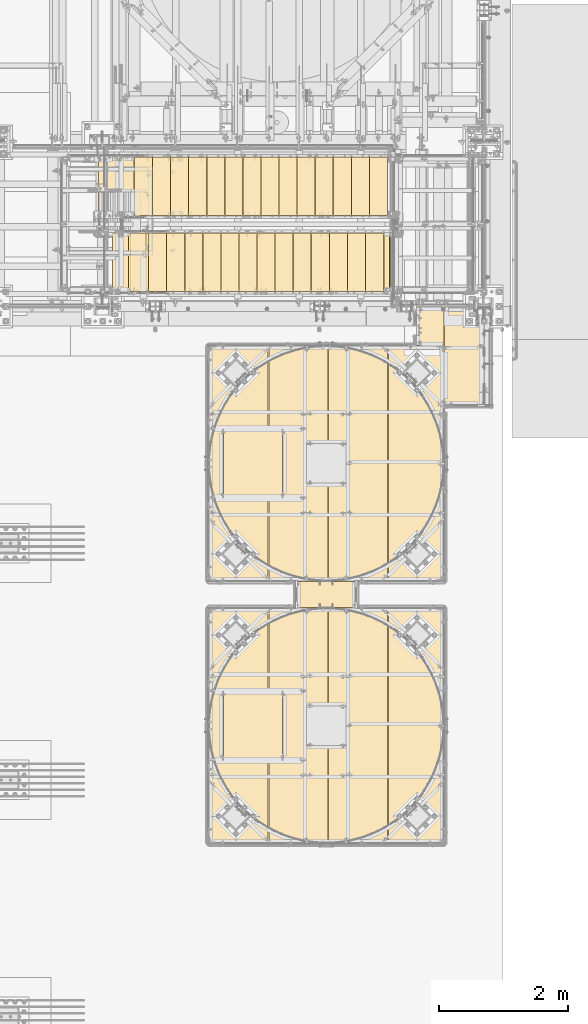
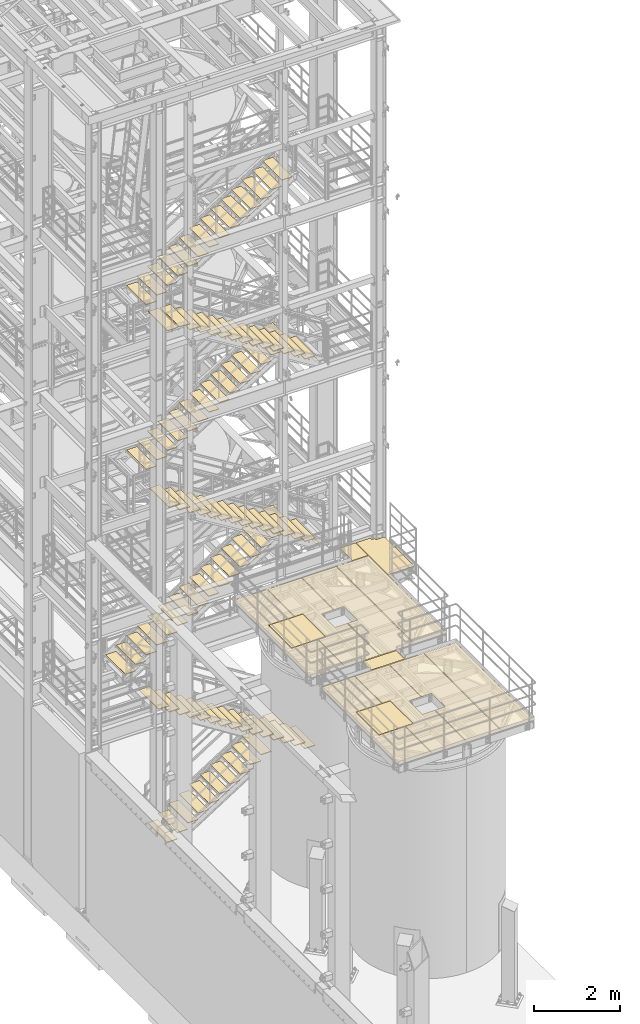
# One storey, part 1875 of 1876: 113 coverings.
"""IFC2X3 building model written with IfcOpenShell, lengths in millimetres."""

from ifc_helpers import new_model, si_unit, frame, origin_with_axes, place, context, subcontext, project, spatial, faceted_brep, material, element, save


model = new_model("IFC2X3")

# Units and contexts
model_context = context("Model", 3, precision=1e-05, world=origin_with_axes())
body_context = subcontext(model_context, "Body", "Model", "MODEL_VIEW")
ifc_project = project(units=[si_unit("LENGTHUNIT", "METRE", prefix="MILLI"), si_unit("AREAUNIT", "SQUARE_METRE"), si_unit("VOLUMEUNIT", "CUBIC_METRE"), si_unit("MASSUNIT", "GRAM", prefix="KILO"), si_unit("TIMEUNIT", "SECOND"), si_unit("PLANEANGLEUNIT", "RADIAN"), si_unit("SOLIDANGLEUNIT", "STERADIAN"), si_unit("THERMODYNAMICTEMPERATUREUNIT", "DEGREE_CELSIUS"), si_unit("LUMINOUSINTENSITYUNIT", "LUMEN")], contexts=[model_context])

# Site, building, storey
site_placement = place(None, origin_with_axes())
site = spatial("IfcSite", under=ifc_project, at=site_placement, CompositionType="ELEMENT")
building_placement = place(site_placement, origin_with_axes())
building = spatial("IfcBuilding", under=site, at=building_placement, Name="Undefined", CompositionType="ELEMENT")
storey_placement = place(building_placement, origin_with_axes())
storey = spatial("IfcBuildingStorey", under=building, at=storey_placement, Name="Undefined", CompositionType="ELEMENT", Elevation=0.0)

# Coverings
ifc_material_1 = material(Name="Undefined/Zero_Density")
covering_1_placement = place(storey_placement, frame((6572.25000460266, -7131.05000084384, 8022.4315), z_axis=(1.0, 0.0, 0.0), x_axis=(0.0, -1.0, 0.0)))
element("IfcCovering", 1, at=covering_1_placement, inside=storey, material=ifc_material_1, Name="SurfaceTreatment", PredefinedType="NOTDEFINED", context=body_context, shape_type="Brep", body=[
    faceted_brep([(7.36690708436072e-11, -0.793499999999767, 427.039367675781), (584.164367675789, -0.793499999999767, 427.039367675769), (584.164367675789, 0.793499999999767, 427.039367675769), (7.36690708436072e-11, 0.793499999999767, 427.039367675781), (584.164367675781, -0.793499999999767, -1.2732925824821e-11), (584.164367675781, 0.793499999999767, -1.2732925824821e-11), (9.09494701772928e-13, -0.793499999999767, 0.0), (9.09494701772928e-13, 0.793499999999767, 0.0)], [[[0, 1, 2, 3]], [[1, 4, 5, 2]], [[4, 6, 7, 5]], [[6, 0, 3, 7]], [[5, 7, 3, 2]], [[6, 4, 1, 0]]]),
])
covering_2_placement = place(storey_placement, frame((5640.38894370825, -11761.7518981934, 8022.4315), z_axis=(-0.999999995651566, -9.32569999677071e-05, 0.0), x_axis=(-9.32569999670443e-05, 0.999999995651566, 0.0)))
element("IfcCovering", 2, at=covering_2_placement, inside=storey, material=ifc_material_1, Name="SurfaceTreatment", PredefinedType="NOTDEFINED", context=body_context, shape_type="Brep", body=[
    faceted_brep([(0.144186362498658, -0.793499999999767, 909.63751220718), (397.016265868699, -0.793499999999767, 909.600463867374), (397.016265868699, 0.793499999999767, 909.600463867374), (0.144186362498658, 0.793499999999767, 909.63751220718), (396.840850829822, -0.793499999999767, -1.35514710564166e-10), (396.840850829822, 0.793499999999767, -1.35514710564166e-10), (9.09494701772928e-13, -0.793499999999767, 0.0), (9.09494701772928e-13, 0.793499999999767, 0.0)], [[[0, 1, 2, 3]], [[1, 4, 5, 2]], [[4, 6, 7, 5]], [[6, 0, 3, 7]], [[5, 7, 3, 2]], [[6, 4, 1, 0]]]),
])
covering_3_placement = place(storey_placement, frame((7004.05187319314, -7715.21439251548, 8022.4315), z_axis=(1.0, 0.0, 0.0), x_axis=(0.0, -1.0, 0.0)))
element("IfcCovering", 3, at=covering_3_placement, inside=storey, material=ifc_material_1, Name="SurfaceTreatment", PredefinedType="NOTDEFINED", context=body_context, shape_type="Brep", body=[
    faceted_brep([(-4.25638972956222e-07, -0.793499999999767, -0.00187377934707911), (-584.164367675781, -0.793499999999767, -0.00187527816342481), (-584.164367675781, 0.793499999999767, -0.00187527816342481), (-4.25638972956222e-07, 0.793499999999767, -0.00187377934707911), (-584.164367675614, -0.793499999999767, 382.585601806901), (-584.164367675614, 0.793499999999767, 382.585601806901), (-514.314392089676, -0.793499999999767, 382.585601806869), (-514.314392089676, 0.793499999999767, 382.585601806869), (-514.314392089638, -0.793499999999767, 468.310638427963), (-514.314392089638, 0.793499999999767, 468.310638427963), (-460.339385986123, -0.793499999999767, 468.310638427938), (-460.339385986123, 0.793499999999767, 468.310638427938), (-460.339385986022, -0.793499999999767, 698.498168945516), (-460.339385986022, 0.793499999999767, 698.498168945516), (914.435607910462, -0.793499999999767, 698.498168944898), (914.435607910462, 0.793499999999767, 698.498168944898), (914.435607910154, -0.793499999999767, -4.14729584008455e-10), (914.435607910154, 0.793499999999767, -4.14729584008455e-10)], [[[0, 1, 2, 3]], [[1, 4, 5, 2]], [[4, 6, 7, 5]], [[6, 8, 9, 7]], [[8, 10, 11, 9]], [[10, 12, 13, 11]], [[12, 14, 15, 13]], [[14, 16, 17, 15]], [[16, 0, 3, 17]], [[5, 7, 9, 11, 13, 15, 17, 3, 2]], [[16, 14, 12, 10, 8, 6, 4, 1, 0]]]),
])
covering_4_placement = place(storey_placement, frame((4876.80473825666, -9232.86440429625, 8022.4315), z_axis=(0.0, 1.0, 0.0), x_axis=(1.0, 0.0, 0.0)))
element("IfcCovering", 4, at=covering_4_placement, inside=storey, material=ifc_material_1, Name="SurfaceTreatment", PredefinedType="NOTDEFINED", context=body_context, shape_type="Brep", body=[
    faceted_brep([(327.027099609375, -0.793499999999767, -2114.49365234375), (-582.6103515625, -0.793499999999767, -2114.49365234375), (-582.6103515625, 0.793499999999767, -2114.49365234375), (327.027099609375, 0.793499999999767, -2114.49365234375), (-582.6103515625, -0.793499999999767, -841.374938964844), (-582.6103515625, 0.793499999999767, -841.374938964844), (-368.299987792969, -0.793499999999767, -841.374938964844), (-368.299987792969, 0.793499999999767, -841.374938964844), (-368.299987792969, -0.793499999999767, 231.77507019043), (-368.299987792969, 0.793499999999767, 231.77507019043), (-582.6103515625, -0.793499999999767, 231.77507019043), (-582.6103515625, 0.793499999999767, 231.77507019043), (-582.6103515625, -0.793499999999767, 1505.00939941406), (-582.6103515625, 0.793499999999767, 1505.00939941406), (327.027099609375, -0.793499999999767, 1505.00939941406), (327.027099609375, 0.793499999999767, 1505.00939941406), (327.027099609375, -0.793499999999767, 0.0), (327.027099609375, 0.793499999999767, 0.0), (9.09494701772928e-13, -0.793499999999767, 0.0), (9.09494701772928e-13, 0.793499999999767, 0.0), (0.0, -0.793499999999767, -609.599975585938), (0.0, 0.793499999999767, -609.599975585938), (327.027099609375, -0.793499999999767, -609.599975585938), (327.027099609375, 0.793499999999767, -609.599975585938)], [[[0, 1, 2, 3]], [[1, 4, 5, 2]], [[4, 6, 7, 5]], [[6, 8, 9, 7]], [[8, 10, 11, 9]], [[10, 12, 13, 11]], [[12, 14, 15, 13]], [[14, 16, 17, 15]], [[16, 18, 19, 17]], [[18, 20, 21, 19]], [[20, 22, 23, 21]], [[22, 0, 3, 23]], [[5, 7, 9, 11, 13, 15, 17, 19, 21, 23, 3, 2]], [[22, 20, 18, 16, 14, 12, 10, 8, 6, 4, 1, 0]]]),
])
covering_5_placement = place(storey_placement, frame((3592.51891061995, -9007.43935546873, 8022.4315), z_axis=(1.0, 0.0, 0.0), x_axis=(0.0, -1.0, 0.0)))
element("IfcCovering", 5, at=covering_5_placement, inside=storey, material=ifc_material_1, Name="SurfaceTreatment", PredefinedType="NOTDEFINED", context=body_context, shape_type="Brep", body=[
    faceted_brep([(0.0, -0.793499999999767, 909.637512207031), (1060.45007324219, -0.793499999999767, 909.637512207031), (1060.45007324219, 0.793499999999767, 909.637512207031), (0.0, 0.793499999999767, 909.637512207031), (1060.45007324219, -0.793499999999767, 0.0), (1060.45007324219, 0.793499999999767, 0.0), (9.09494701772928e-13, -0.793499999999767, 0.0), (9.09494701772928e-13, 0.793499999999767, 0.0)], [[[0, 1, 2, 3]], [[1, 4, 5, 2]], [[4, 6, 7, 5]], [[6, 0, 3, 7]], [[5, 7, 3, 2]], [[6, 4, 1, 0]]]),
])
covering_6_placement = place(storey_placement, frame((6142.07478332581, -7727.91436167475, 8022.4315), z_axis=(0.999999999962502, -8.65999999950873e-06, 0.0), x_axis=(-8.6599999995572e-06, -0.999999999962502, 0.0)))
element("IfcCovering", 6, at=covering_6_placement, inside=storey, material=ifc_material_1, Name="SurfaceTreatment", PredefinedType="NOTDEFINED", context=body_context, shape_type="Brep", body=[
    faceted_brep([(-0.00731827155505016, -0.793499999999767, 849.277099609553), (3619.43627929786, -0.793499999999767, 849.308471678866), (3619.43627929786, 0.793499999999767, 849.308471678866), (-0.00731827155505016, 0.793499999999767, 849.277099609553), (3619.44360351638, -0.793499999999767, -1.96450855582952e-09), (3619.44360351638, 0.793499999999767, -1.96450855582952e-09), (9.09494701772928e-13, -0.793499999999767, 0.0), (9.09494701772928e-13, 0.793499999999767, 0.0)], [[[0, 1, 2, 3]], [[1, 4, 5, 2]], [[4, 6, 7, 5]], [[6, 0, 3, 7]], [[5, 7, 3, 2]], [[6, 4, 1, 0]]]),
])
covering_7_placement = place(storey_placement, frame((5216.53091929245, -11347.3580079976, 8022.43150000058), z_axis=(0.0, 1.0, 0.0), x_axis=(1.0, 0.0, 0.0)))
element("IfcCovering", 7, at=covering_7_placement, inside=storey, material=ifc_material_1, Name="SurfaceTreatment", PredefinedType="NOTDEFINED", context=body_context, shape_type="Brep", body=[
    faceted_brep([(0.0130641348341669, -0.793499999999767, 1504.89599609375), (269.873809814421, -0.793499999999767, 1504.8936767576), (269.873809814421, 0.793499999999767, 1504.8936767576), (0.0130641348341669, 0.793499999999767, 1504.89599609375), (269.87380981447, -0.793499999999767, 2114.55151367176), (269.87380981447, 0.793499999999767, 2114.55151367176), (0.0183281973177145, -0.793499999999767, 2114.55151367197), (0.0183281973177145, 0.793499999999767, 2114.55151367197), (0.0313720779013238, -0.793499999999767, 3619.44360351597), (0.0313720779013238, 0.793499999999767, 3619.44360351597), (909.668884277481, -0.793499999999767, 3619.44360351525), (909.668884277481, 0.793499999999767, 3619.44360351525), (909.637512206879, -0.793499999999767, -9.60426405072212e-10), (909.637512206879, 0.793499999999767, -9.60426405072212e-10), (9.09494701772928e-13, -0.793499999999767, 0.0), (9.09494701772928e-13, 0.793499999999767, 0.0)], [[[0, 1, 2, 3]], [[1, 4, 5, 2]], [[4, 6, 7, 5]], [[6, 8, 9, 7]], [[8, 10, 11, 9]], [[10, 12, 13, 11]], [[12, 14, 15, 13]], [[14, 0, 3, 15]], [[5, 7, 9, 11, 13, 15, 3, 2]], [[14, 12, 10, 8, 6, 4, 1, 0]]]),
])
covering_8_placement = place(storey_placement, frame((4281.49144479969, -9001.0330810547, 8022.4315), z_axis=(-1.0, 0.0, 0.0), x_axis=(0.0, 1.0, 0.0)))
element("IfcCovering", 8, at=covering_8_placement, inside=storey, material=ifc_material_1, Name="SurfaceTreatment", PredefinedType="NOTDEFINED", context=body_context, shape_type="Brep", body=[
    faceted_brep([(-1073.15063476562, -0.793499999999767, -5.18411980010569e-11), (-2346.32470703125, -0.793499999999767, -1.12777343019843e-10), (-2346.32470703125, 0.793499999999767, -1.12777343019843e-10), (-1073.15063476562, 0.793499999999767, -5.18411980010569e-11), (-2346.32470703125, -0.793499999999767, 909.637451171875), (-2346.32470703125, 0.793499999999767, 909.637451171875), (1273.17810058594, -0.793499999999767, 909.606201171875), (1273.17810058594, 0.793499999999767, 909.606201171875), (1273.17810058594, -0.793499999999767, 6.09361450187862e-11), (1273.17810058594, 0.793499999999767, 6.09361450187862e-11), (9.09494701772928e-13, -0.793499999999767, 0.0), (9.09494701772928e-13, 0.793499999999767, 0.0), (0.0, -0.793499999999767, 700.086669921875), (0.0, 0.793499999999767, 700.086669921875), (-1073.15063476562, -0.793499999999767, 700.086669921875), (-1073.15063476562, 0.793499999999767, 700.086669921875)], [[[0, 1, 2, 3]], [[1, 4, 5, 2]], [[4, 6, 7, 5]], [[6, 8, 9, 7]], [[8, 10, 11, 9]], [[10, 12, 13, 11]], [[12, 14, 15, 13]], [[14, 0, 3, 15]], [[5, 7, 9, 11, 13, 15, 3, 2]], [[14, 12, 10, 8, 6, 4, 1, 0]]]),
])
covering_9_placement = place(storey_placement, frame((4876.80142382026, -13284.1644531244, 8022.4315), z_axis=(0.0, 1.0, 0.0), x_axis=(1.0, 0.0, 0.0)))
element("IfcCovering", 9, at=covering_9_placement, inside=storey, material=ifc_material_1, Name="SurfaceTreatment", PredefinedType="NOTDEFINED", context=body_context, shape_type="Brep", body=[
    faceted_brep([(327.027099609375, -0.793499999999767, -2114.49365234375), (-582.6103515625, -0.793499999999767, -2114.49365234375), (-582.6103515625, 0.793499999999767, -2114.49365234375), (327.027099609375, 0.793499999999767, -2114.49365234375), (-582.6103515625, -0.793499999999767, -841.374938964844), (-582.6103515625, 0.793499999999767, -841.374938964844), (-368.299987792969, -0.793499999999767, -841.374938964844), (-368.299987792969, 0.793499999999767, -841.374938964844), (-368.299987792969, -0.793499999999767, 231.77507019043), (-368.299987792969, 0.793499999999767, 231.77507019043), (-582.6103515625, -0.793499999999767, 231.77507019043), (-582.6103515625, 0.793499999999767, 231.77507019043), (-582.6103515625, -0.793499999999767, 1505.00939941406), (-582.6103515625, 0.793499999999767, 1505.00939941406), (327.027099609375, -0.793499999999767, 1505.00939941406), (327.027099609375, 0.793499999999767, 1505.00939941406), (327.027099609375, -0.793499999999767, 0.0), (327.027099609375, 0.793499999999767, 0.0), (9.09494701772928e-13, -0.793499999999767, 0.0), (9.09494701772928e-13, 0.793499999999767, 0.0), (0.0, -0.793499999999767, -609.599975585938), (0.0, 0.793499999999767, -609.599975585938), (327.027099609375, -0.793499999999767, -609.599975585938), (327.027099609375, 0.793499999999767, -609.599975585938)], [[[0, 1, 2, 3]], [[1, 4, 5, 2]], [[4, 6, 7, 5]], [[6, 8, 9, 7]], [[8, 10, 11, 9]], [[10, 12, 13, 11]], [[12, 14, 15, 13]], [[14, 16, 17, 15]], [[16, 18, 19, 17]], [[18, 20, 21, 19]], [[20, 22, 23, 21]], [[22, 0, 3, 23]], [[5, 7, 9, 11, 13, 15, 17, 19, 21, 23, 3, 2]], [[22, 20, 18, 16, 14, 12, 10, 8, 6, 4, 1, 0]]]),
])
covering_10_placement = place(storey_placement, frame((3592.51559618354, -13058.7394042969, 8022.4315), z_axis=(1.0, 0.0, 0.0), x_axis=(0.0, -1.0, 0.0)))
element("IfcCovering", 10, at=covering_10_placement, inside=storey, material=ifc_material_1, Name="SurfaceTreatment", PredefinedType="NOTDEFINED", context=body_context, shape_type="Brep", body=[
    faceted_brep([(0.0, -0.793499999999767, 909.637512207031), (1060.45007324219, -0.793499999999767, 909.637512207031), (1060.45007324219, 0.793499999999767, 909.637512207031), (0.0, 0.793499999999767, 909.637512207031), (1060.45007324219, -0.793499999999767, 0.0), (1060.45007324219, 0.793499999999767, 0.0), (9.09494701772928e-13, -0.793499999999767, 0.0), (9.09494701772928e-13, 0.793499999999767, 0.0)], [[[0, 1, 2, 3]], [[1, 4, 5, 2]], [[4, 6, 7, 5]], [[6, 0, 3, 7]], [[5, 7, 3, 2]], [[6, 4, 1, 0]]]),
])
covering_11_placement = place(storey_placement, frame((6142.07146888941, -11779.2144470212, 8022.4315), z_axis=(0.999999999962502, -8.65999999950873e-06, 0.0), x_axis=(-8.6599999995572e-06, -0.999999999962502, 0.0)))
element("IfcCovering", 11, at=covering_11_placement, inside=storey, material=ifc_material_1, Name="SurfaceTreatment", PredefinedType="NOTDEFINED", context=body_context, shape_type="Brep", body=[
    faceted_brep([(-0.00731827155505016, -0.793499999999767, 849.277099609553), (3619.43627929476, -0.793499999999767, 849.308410644945), (3619.43627929476, 0.793499999999767, 849.308410644945), (-0.00731827155505016, 0.793499999999767, 849.277099609553), (3619.44360351638, -0.793499999999767, -1.96450855582952e-09), (3619.44360351638, 0.793499999999767, -1.96450855582952e-09), (9.09494701772928e-13, -0.793499999999767, 0.0), (9.09494701772928e-13, 0.793499999999767, 0.0)], [[[0, 1, 2, 3]], [[1, 4, 5, 2]], [[4, 6, 7, 5]], [[6, 0, 3, 7]], [[5, 7, 3, 2]], [[6, 4, 1, 0]]]),
])
covering_12_placement = place(storey_placement, frame((5216.52760485741, -15398.6580568249, 8022.43150000058), z_axis=(0.0, 1.0, 0.0), x_axis=(1.0, 0.0, 0.0)))
element("IfcCovering", 12, at=covering_12_placement, inside=storey, material=ifc_material_1, Name="SurfaceTreatment", PredefinedType="NOTDEFINED", context=body_context, shape_type="Brep", body=[
    faceted_brep([(0.0130641348341669, -0.793499999999767, 1504.89599609375), (269.873809814421, -0.793499999999767, 1504.8936767576), (269.873809814421, 0.793499999999767, 1504.8936767576), (0.0130641348341669, 0.793499999999767, 1504.89599609375), (269.87380981447, -0.793499999999767, 2114.55151367176), (269.87380981447, 0.793499999999767, 2114.55151367176), (0.0183281973177145, -0.793499999999767, 2114.55151367197), (0.0183281973177145, 0.793499999999767, 2114.55151367197), (0.0313720779013238, -0.793499999999767, 3619.44360351597), (0.0313720779013238, 0.793499999999767, 3619.44360351597), (909.668884277481, -0.793499999999767, 3619.44360351525), (909.668884277481, 0.793499999999767, 3619.44360351525), (909.637512206879, -0.793499999999767, -9.60426405072212e-10), (909.637512206879, 0.793499999999767, -9.60426405072212e-10), (9.09494701772928e-13, -0.793499999999767, 0.0), (9.09494701772928e-13, 0.793499999999767, 0.0)], [[[0, 1, 2, 3]], [[1, 4, 5, 2]], [[4, 6, 7, 5]], [[6, 8, 9, 7]], [[8, 10, 11, 9]], [[10, 12, 13, 11]], [[12, 14, 15, 13]], [[14, 0, 3, 15]], [[5, 7, 9, 11, 13, 15, 3, 2]], [[14, 12, 10, 8, 6, 4, 1, 0]]]),
])
covering_13_placement = place(storey_placement, frame((4281.48813036329, -13052.3331298828, 8022.4315), z_axis=(-1.0, 0.0, 0.0), x_axis=(0.0, 1.0, 0.0)))
element("IfcCovering", 13, at=covering_13_placement, inside=storey, material=ifc_material_1, Name="SurfaceTreatment", PredefinedType="NOTDEFINED", context=body_context, shape_type="Brep", body=[
    faceted_brep([(-1073.15063476562, -0.793499999999767, -5.18411980010569e-11), (-2346.32470703125, -0.793499999999767, -1.12777343019843e-10), (-2346.32470703125, 0.793499999999767, -1.12777343019843e-10), (-1073.15063476562, 0.793499999999767, -5.18411980010569e-11), (-2346.32470703125, -0.793499999999767, 909.637451171875), (-2346.32470703125, 0.793499999999767, 909.637451171875), (1273.17810058594, -0.793499999999767, 909.606201171875), (1273.17810058594, 0.793499999999767, 909.606201171875), (1273.17810058594, -0.793499999999767, 6.09361450187862e-11), (1273.17810058594, 0.793499999999767, 6.09361450187862e-11), (9.09494701772928e-13, -0.793499999999767, 0.0), (9.09494701772928e-13, 0.793499999999767, 0.0), (0.0, -0.793499999999767, 700.086669921875), (0.0, 0.793499999999767, 700.086669921875), (-1073.15063476562, -0.793499999999767, 700.086669921875), (-1073.15063476562, 0.793499999999767, 700.086669921875)], [[[0, 1, 2, 3]], [[1, 4, 5, 2]], [[4, 6, 7, 5]], [[6, 8, 9, 7]], [[8, 10, 11, 9]], [[10, 12, 13, 11]], [[12, 14, 15, 13]], [[14, 0, 3, 15]], [[5, 7, 9, 11, 13, 15, 3, 2]], [[14, 12, 10, 8, 6, 4, 1, 0]]]),
])
for number, where, z_axis, x_axis, name in (
    (14, (3270.25000124689, -5973.76300114732, 15213.6592592597), (0.0, -1.0, 0.0), (-1.0, 0.0, 0.0), "SurfaceTreatment"),
    (15, (5848.34999716895, -5710.23700114169, 17810.1037047545), (0.0, 1.0, 0.0), (1.0, 0.0, 0.0), "SurfaceTreatment"),
    (16, (5568.94999692322, -5710.23700114223, 17637.0074083463), (0.0, 1.0, 0.0), (1.0, 0.0, 0.0), "SurfaceTreatment"),
    (17, (5289.5499966775, -5710.23700114276, 17463.9111119382), (0.0, 1.0, 0.0), (1.0, 0.0, 0.0), "SurfaceTreatment"),
    (18, (5010.14999643177, -5710.23700114329, 17290.81481553), (0.0, 1.0, 0.0), (1.0, 0.0, 0.0), "SurfaceTreatment"),
    (19, (4730.74999618604, -5710.23700114382, 17117.7185191218), (0.0, 1.0, 0.0), (1.0, 0.0, 0.0), "SurfaceTreatment"),
    (20, (4451.34999594032, -5710.23700114436, 16944.6222227137), (0.0, 1.0, 0.0), (1.0, 0.0, 0.0), "SurfaceTreatment"),
    (21, (4171.94999569459, -5710.23700114489, 16771.5259263055), (0.0, 1.0, 0.0), (1.0, 0.0, 0.0), "SurfaceTreatment"),
    (22, (3892.54999544887, -5710.23700114542, 16598.4296298974), (0.0, 1.0, 0.0), (1.0, 0.0, 0.0), "SurfaceTreatment"),
    (23, (3613.14999520314, -5710.23700114596, 16425.3333334892), (0.0, 1.0, 0.0), (1.0, 0.0, 0.0), "SurfaceTreatment"),
    (24, (3333.74999495741, -5710.23700114644, 16252.2370370811), (0.0, 1.0, 0.0), (1.0, 0.0, 0.0), "SurfaceTreatment"),
    (25, (3054.34999471169, -5710.23700114697, 16079.1407406729), (0.0, 1.0, 0.0), (1.0, 0.0, 0.0), "SurfaceTreatment"),
    (26, (2774.94999446596, -5710.2370011475, 15906.0444442647), (0.0, 1.0, 0.0), (1.0, 0.0, 0.0), "SurfaceTreatment"),
    (27, (2495.54999422024, -5710.23700114804, 15732.9481478566), (0.0, 1.0, 0.0), (1.0, 0.0, 0.0), "SurfaceTreatment"),
    (28, (3549.65000116849, -5973.76300114727, 15040.5629629634), (0.0, -1.0, 0.0), (-1.0, 0.0, 0.0), "SurfaceTreatment"),
    (29, (3829.05000109009, -5973.76300114701, 14867.4666666671), (0.0, -1.0, 0.0), (-1.0, 0.0, 0.0), "SurfaceTreatment"),
    (30, (2990.85000132529, -5973.76300114758, 15386.755555556), (0.0, -1.0, 0.0), (-1.0, 0.0, 0.0), "SurfaceTreatment"),
    (31, (4108.45000101169, -5973.76300114696, 14694.3703703708), (0.0, -1.0, 0.0), (-1.0, 0.0, 0.0), "SurfaceTreatment"),
    (32, (4387.85000093329, -5973.76300114669, 14521.2740740745), (0.0, -1.0, 0.0), (-1.0, 0.0, 0.0), "SurfaceTreatment"),
    (33, (4667.25000085489, -5973.76300114664, 14348.1777777782), (0.0, -1.0, 0.0), (-1.0, 0.0, 0.0), "SurfaceTreatment"),
    (34, (4946.65000077649, -5973.76300114638, 14175.0814814819), (0.0, -1.0, 0.0), (-1.0, 0.0, 0.0), "SurfaceTreatment"),
    (35, (5226.05000069809, -5973.76300114633, 14001.9851851856), (0.0, -1.0, 0.0), (-1.0, 0.0, 0.0), "SurfaceTreatment"),
    (36, (5505.45000061969, -5973.76300114607, 13828.8888888893), (0.0, -1.0, 0.0), (-1.0, 0.0, 0.0), "SurfaceTreatment"),
    (37, (5784.85000054129, -5973.76300114601, 13655.792592593), (0.0, -1.0, 0.0), (-1.0, 0.0, 0.0), "SurfaceTreatment"),
    (38, (6064.25000046289, -5973.76300114575, 13482.6962962967), (0.0, -1.0, 0.0), (-1.0, 0.0, 0.0), "SurfaceTreatment"),
    (39, (5848.35000008514, -5710.23700114557, 13137.7266666865), (0.0, 1.0, 0.0), (1.0, 0.0, 0.0), "SurfaceTreatment"),
    (40, (5568.95000017887, -5710.23700114557, 12965.8533333532), (0.0, 1.0, 0.0), (1.0, 0.0, 0.0), "SurfaceTreatment"),
    (41, (5289.55000027259, -5710.23700114557, 12793.9800000199), (0.0, 1.0, 0.0), (1.0, 0.0, 0.0), "SurfaceTreatment"),
    (42, (5010.15000036631, -5710.23700114557, 12622.1066666865), (0.0, 1.0, 0.0), (1.0, 0.0, 0.0), "SurfaceTreatment"),
    (43, (4730.75000046003, -5710.23700114557, 12450.2333333532), (0.0, 1.0, 0.0), (1.0, 0.0, 0.0), "SurfaceTreatment"),
    (44, (4451.35000055376, -5710.23700114557, 12278.3600000199), (0.0, 1.0, 0.0), (1.0, 0.0, 0.0), "SurfaceTreatment"),
    (45, (4171.95000064748, -5710.23700114557, 12106.4866666865), (0.0, 1.0, 0.0), (1.0, 0.0, 0.0), "SurfaceTreatment"),
    (46, (3892.5500007412, -5710.23700114557, 11934.6133333532), (0.0, 1.0, 0.0), (1.0, 0.0, 0.0), "SurfaceTreatment"),
    (47, (3613.15000083493, -5710.23700114557, 11762.7400000199), (0.0, 1.0, 0.0), (1.0, 0.0, 0.0), "SurfaceTreatment"),
    (48, (3333.75000092865, -5710.23700114557, 11590.8666666865), (0.0, 1.0, 0.0), (1.0, 0.0, 0.0), "SurfaceTreatment"),
    (49, (3054.35000102237, -5710.23700114557, 11418.9933333532), (0.0, 1.0, 0.0), (1.0, 0.0, 0.0), "SurfaceTreatment"),
    (50, (2774.95000111609, -5710.23700114557, 11247.1200000199), (0.0, 1.0, 0.0), (1.0, 0.0, 0.0), "SurfaceTreatment"),
    (51, (2495.55000120982, -5710.23700114557, 11075.2466666865), (0.0, 1.0, 0.0), (1.0, 0.0, 0.0), "SurfaceTreatment"),
    (52, (2216.15000130354, -5710.23700114557, 10903.3733333532), (0.0, 1.0, 0.0), (1.0, 0.0, 0.0), "SurfaceTreatment"),
    (53, (2432.05000121991, -5973.76300114394, 10559.6266675622), (0.0, -1.0, 0.0), (-1.0, 0.0, 0.0), "SurfaceTreatment"),
    (54, (2711.45000115037, -5973.76300114419, 10387.753334165), (0.0, -1.0, 0.0), (-1.0, 0.0, 0.0), "SurfaceTreatment"),
    (55, (2990.85000108083, -5973.76300114444, 10215.8800007678), (0.0, -1.0, 0.0), (-1.0, 0.0, 0.0), "SurfaceTreatment"),
    (56, (3270.25000101129, -5973.7630011447, 10044.0066673706), (0.0, -1.0, 0.0), (-1.0, 0.0, 0.0), "SurfaceTreatment"),
    (57, (3549.65000094175, -5973.76300114495, 9872.13333397344), (0.0, -1.0, 0.0), (-1.0, 0.0, 0.0), "SurfaceTreatment"),
    (58, (3829.05000087221, -5973.7630011452, 9700.26000057626), (0.0, -1.0, 0.0), (-1.0, 0.0, 0.0), "SurfaceTreatment"),
    (59, (4108.45000080267, -5973.76300114546, 9528.38666717907), (0.0, -1.0, 0.0), (-1.0, 0.0, 0.0), "SurfaceTreatment"),
    (60, (4387.85000073313, -5973.76300114571, 9356.51333378189), (0.0, -1.0, 0.0), (-1.0, 0.0, 0.0), "SurfaceTreatment"),
    (61, (4667.25000066359, -5973.76300114597, 9184.64000038471), (0.0, -1.0, 0.0), (-1.0, 0.0, 0.0), "SurfaceTreatment"),
    (62, (4946.65000059405, -5973.76300114622, 9012.76666698753), (0.0, -1.0, 0.0), (-1.0, 0.0, 0.0), "SurfaceTreatment"),
    (63, (5226.05000052451, -5973.76300114647, 8840.89333359034), (0.0, -1.0, 0.0), (-1.0, 0.0, 0.0), "SurfaceTreatment"),
    (64, (5505.45000045497, -5973.76300114673, 8669.02000019316), (0.0, -1.0, 0.0), (-1.0, 0.0, 0.0), "SurfaceTreatment"),
    (65, (5784.85000038543, -5973.76300114698, 8497.14666679598), (0.0, -1.0, 0.0), (-1.0, 0.0, 0.0), "SurfaceTreatment"),
    (66, (6064.25000031588, -5973.76300114723, 8325.27333339879), (0.0, -1.0, 0.0), (-1.0, 0.0, 0.0), "SurfaceTreatment"),
    (67, (5848.34999446524, -5710.23700113625, 7975.5999987069), (0.0, 1.0, 0.0), (1.0, 0.0, 0.0), "SurfaceTreatment"),
    (68, (5568.94999485534, -5710.23700113625, 7797.79999878767), (0.0, 1.0, 0.0), (1.0, 0.0, 0.0), "SurfaceTreatment"),
    (69, (5289.54999524543, -5710.23700113625, 7619.99999886843), (0.0, 1.0, 0.0), (1.0, 0.0, 0.0), "SurfaceTreatment"),
    (70, (5010.14999563552, -5710.23700113625, 7442.1999989492), (0.0, 1.0, 0.0), (1.0, 0.0, 0.0), "SurfaceTreatment"),
    (71, (4730.74999602562, -5710.23700113625, 7264.39999902997), (0.0, 1.0, 0.0), (1.0, 0.0, 0.0), "SurfaceTreatment"),
    (72, (4451.34999641571, -5710.23700113625, 7086.59999911074), (0.0, 1.0, 0.0), (1.0, 0.0, 0.0), "SurfaceTreatment"),
    (73, (4171.94999680581, -5710.23700113625, 6908.7999991915), (0.0, 1.0, 0.0), (1.0, 0.0, 0.0), "SurfaceTreatment"),
    (74, (3892.5499971959, -5710.23700113625, 6730.99999927227), (0.0, 1.0, 0.0), (1.0, 0.0, 0.0), "SurfaceTreatment"),
    (75, (3613.14999758599, -5710.23700113625, 6553.19999935304), (0.0, 1.0, 0.0), (1.0, 0.0, 0.0), "SurfaceTreatment"),
    (76, (3333.74999797608, -5710.23700113625, 6375.39999943381), (0.0, 1.0, 0.0), (1.0, 0.0, 0.0), "SurfaceTreatment"),
    (77, (3054.34999836618, -5710.23700113625, 6197.59999951457), (0.0, 1.0, 0.0), (1.0, 0.0, 0.0), "SurfaceTreatment"),
    (78, (2774.94999875627, -5710.23700113625, 6019.79999959534), (0.0, 1.0, 0.0), (1.0, 0.0, 0.0), "SurfaceTreatment"),
    (79, (2495.54999914636, -5710.23700113625, 5841.99999967611), (0.0, 1.0, 0.0), (1.0, 0.0, 0.0), "SurfaceTreatment"),
    (80, (2216.14999953646, -5710.23700113625, 5664.19999975688), (0.0, 1.0, 0.0), (1.0, 0.0, 0.0), "SurfaceTreatment"),
    (81, (1936.74999992655, -5710.23700113625, 5486.39999983764), (0.0, 1.0, 0.0), (1.0, 0.0, 0.0), "SurfaceTreatment"),
    (82, (1657.35000031664, -5710.23700113625, 5308.59999991841), (0.0, 1.0, 0.0), (1.0, 0.0, 0.0), "SurfaceTreatment"),
    (83, (2152.65000578957, -5973.76300113422, 4953.5474137952), (0.0, -1.0, 0.0), (-1.0, 0.0, 0.0), "SurfaceTreatment"),
    (84, (2432.05000547176, -5973.76300113406, 4776.29482758856), (0.0, -1.0, 0.0), (-1.0, 0.0, 0.0), "SurfaceTreatment"),
    (85, (2711.45000515396, -5973.76300113389, 4599.04224138192), (0.0, -1.0, 0.0), (-1.0, 0.0, 0.0), "SurfaceTreatment"),
    (86, (2990.85000483615, -5973.76300113373, 4421.78965517528), (0.0, -1.0, 0.0), (-1.0, 0.0, 0.0), "SurfaceTreatment"),
    (87, (3270.25000451835, -5973.76300113357, 4244.53706896864), (0.0, -1.0, 0.0), (-1.0, 0.0, 0.0), "SurfaceTreatment"),
    (88, (3549.65000420054, -5973.76300113341, 4067.28448276199), (0.0, -1.0, 0.0), (-1.0, 0.0, 0.0), "SurfaceTreatment"),
    (89, (3829.05000388274, -5973.76300113325, 3890.03189655535), (0.0, -1.0, 0.0), (-1.0, 0.0, 0.0), "SurfaceTreatment"),
    (90, (4108.45000356493, -5973.76300113309, 3712.77931034871), (0.0, -1.0, 0.0), (-1.0, 0.0, 0.0), "SurfaceTreatment"),
    (91, (4387.85000324712, -5973.76300113293, 3535.52672414207), (0.0, -1.0, 0.0), (-1.0, 0.0, 0.0), "SurfaceTreatment"),
    (92, (4667.25000292932, -5973.76300113277, 3358.27413793542), (0.0, -1.0, 0.0), (-1.0, 0.0, 0.0), "SurfaceTreatment"),
    (93, (4946.65000261151, -5973.76300113261, 3181.02155172878), (0.0, -1.0, 0.0), (-1.0, 0.0, 0.0), "SurfaceTreatment"),
    (94, (5226.05000229371, -5973.76300113245, 3003.76896552214), (0.0, -1.0, 0.0), (-1.0, 0.0, 0.0), "SurfaceTreatment"),
    (95, (5505.4500019759, -5973.76300113228, 2826.5163793155), (0.0, -1.0, 0.0), (-1.0, 0.0, 0.0), "SurfaceTreatment"),
    (96, (5784.85000165809, -5973.76300113212, 2649.26379310885), (0.0, -1.0, 0.0), (-1.0, 0.0, 0.0), "SurfaceTreatment"),
    (97, (6064.25000134029, -5973.76300113196, 2472.01120690221), (0.0, -1.0, 0.0), (-1.0, 0.0, 0.0), "SurfaceTreatment"),
    (98, (5848.35000066187, -5710.23700121136, 2117.50603396813), (0.0, 1.0, 0.0), (1.0, 0.0, 0.0), "SurfaceTreatment"),
    (99, (5289.55000060753, -5710.23700121136, 1763.00086163999), (0.0, 1.0, 0.0), (1.0, 0.0, 0.0), "SurfaceTreatment"),
    (100, (5010.15000058036, -5710.23700121136, 1585.74827547592), (0.0, 1.0, 0.0), (1.0, 0.0, 0.0), "SurfaceTreatment"),
    (101, (4730.75000055319, -5710.23700121136, 1408.49568931185), (0.0, 1.0, 0.0), (1.0, 0.0, 0.0), "SurfaceTreatment"),
    (102, (4451.35000052602, -5710.23700121136, 1231.24310314779), (0.0, 1.0, 0.0), (1.0, 0.0, 0.0), "SurfaceTreatment"),
    (103, (4171.95000049885, -5710.23700121136, 1053.99051698372), (0.0, 1.0, 0.0), (1.0, 0.0, 0.0), "SurfaceTreatment"),
    (104, (3892.55000047169, -5710.23700121136, 876.737930819678), (0.0, 1.0, 0.0), (1.0, 0.0, 0.0), "SurfaceTreatment"),
    (105, (3613.15000044451, -5710.23700121136, 699.485344655642), (0.0, 1.0, 0.0), (1.0, 0.0, 0.0), "SurfaceTreatment"),
    (106, (3333.75000041734, -5710.23700121136, 522.232758491605), (0.0, 1.0, 0.0), (1.0, 0.0, 0.0), "SurfaceTreatment"),
    (107, (3054.35000039017, -5710.23700121136, 344.980172327555), (0.0, 1.0, 0.0), (1.0, 0.0, 0.0), "SurfaceTreatment"),
    (108, (2774.950000363, -5710.23700121136, 167.727586163495), (0.0, 1.0, 0.0), (1.0, 0.0, 0.0), "SurfaceTreatment"),
):
    element("IfcCovering", number, at=place(storey_placement, frame(where, z_axis=z_axis, x_axis=x_axis)), inside=storey, material=ifc_material_1, Name=name, PredefinedType="NOTDEFINED", context=body_context, shape_type="Brep", body=[
        faceted_brep([(-9.09494701772928e-13, -9.525, -1.81898940354586e-12), (0.0, -9.52499999999964, 904.8740234375), (0.0, 9.52499999999964, 904.8740234375), (-9.09494701772928e-13, 9.525, -1.81898940354586e-12), (276.225006103516, -9.52499999999964, 904.8740234375), (276.225006103516, 9.52499999999964, 904.8740234375), (276.225006103516, -9.52499999999964, 0.0), (276.225006103516, 9.52499999999964, 0.0)], [[[0, 1, 2, 3]], [[1, 4, 5, 2]], [[4, 6, 7, 5]], [[6, 0, 3, 7]], [[5, 7, 3, 2]], [[6, 4, 1, 0]]]),
    ])
ifc_material_2 = material(Name="Undefined/Tiles")
covering_14_placement = place(storey_placement, frame((6172.19999694572, -5975.34987682352, 8162.42500058556), z_axis=(0.0, -1.0, 0.0), x_axis=(-1.0, 0.0, 0.0)))
element("IfcCovering", 109, at=covering_14_placement, inside=storey, material=ifc_material_2, Name="SurfaceTreatment", PredefinedType="NOTDEFINED", context=body_context, shape_type="Brep", body=[
    faceted_brep([(0.0, -0.5, 901.700012207031), (101.599998474121, -0.5, 901.700012207031), (101.599998474121, 0.5, 901.700012207031), (0.0, 0.5, 901.700012207031), (101.599998474121, -0.5, 0.0), (101.599998474121, 0.5, 0.0), (0.0, -0.5, 0.0), (0.0, 0.5, 0.0)], [[[0, 1, 2, 3]], [[1, 4, 5, 2]], [[4, 6, 7, 5]], [[6, 0, 3, 7]], [[5, 7, 3, 2]], [[6, 4, 1, 0]]]),
])
covering_15_placement = place(storey_placement, frame((6159.49999998204, -5975.35000104997, 13318.6250005856), z_axis=(0.0, -1.0, 0.0), x_axis=(-1.0, 0.0, 0.0)))
element("IfcCovering", 110, at=covering_15_placement, inside=storey, material=ifc_material_2, Name="SurfaceTreatment", PredefinedType="NOTDEFINED", context=body_context, shape_type="Brep", body=[
    faceted_brep([(0.0, -0.5, 901.700012207031), (88.9000015258789, -0.5, 901.700012207031), (88.9000015258789, 0.5, 901.700012207031), (0.0, 0.5, 901.700012207031), (88.9000015258789, -0.5, 0.0), (88.9000015258789, 0.5, 0.0), (0.0, -0.5, 0.0), (0.0, 0.5, 0.0)], [[[0, 1, 2, 3]], [[1, 4, 5, 2]], [[4, 6, 7, 5]], [[6, 0, 3, 7]], [[5, 7, 3, 2]], [[6, 4, 1, 0]]]),
])
for number, where, z_axis, x_axis, name in (
    (111, (2216.15000014946, -4805.36200114167, 15559.8518519777), (0.0, -1.0, 0.0), (1.0, 0.0, 0.0), "SurfaceTreatment"),
    (112, (2397.12504446461, -6878.6380024193, 15559.861071429), (0.0, 1.0, 0.0), (-1.0, 0.0, 0.0), "SurfaceTreatment"),
    (113, (2711.45003777163, -6878.6380024193, 15559.8518518516), (0.0, 1.0, 0.0), (-1.0, 0.0, 0.0), "SurfaceTreatment"),
):
    element("IfcCovering", number, at=place(storey_placement, frame(where, z_axis=z_axis, x_axis=x_axis)), inside=storey, material=ifc_material_1, Name=name, PredefinedType="NOTDEFINED", context=body_context, shape_type="Brep", body=[
        faceted_brep([(-9.09494701772928e-13, -9.525, -1.81898940354586e-12), (-1.63709046319127e-11, -9.52499999999964, 904.875915527344), (-1.63709046319127e-11, 9.52499999999964, 904.875915527344), (-9.09494701772928e-13, 9.525, -1.81898940354586e-12), (276.225006103516, -9.52499999999964, 904.875915527344), (276.225006103516, 9.52499999999964, 904.875915527344), (276.225006103516, -9.52499999999964, 0.0), (276.225006103516, 9.52499999999964, 0.0)], [[[0, 1, 2, 3]], [[1, 4, 5, 2]], [[4, 6, 7, 5]], [[6, 0, 3, 7]], [[5, 7, 3, 2]], [[6, 4, 1, 0]]]),
    ])

save(model, "model.ifc")
